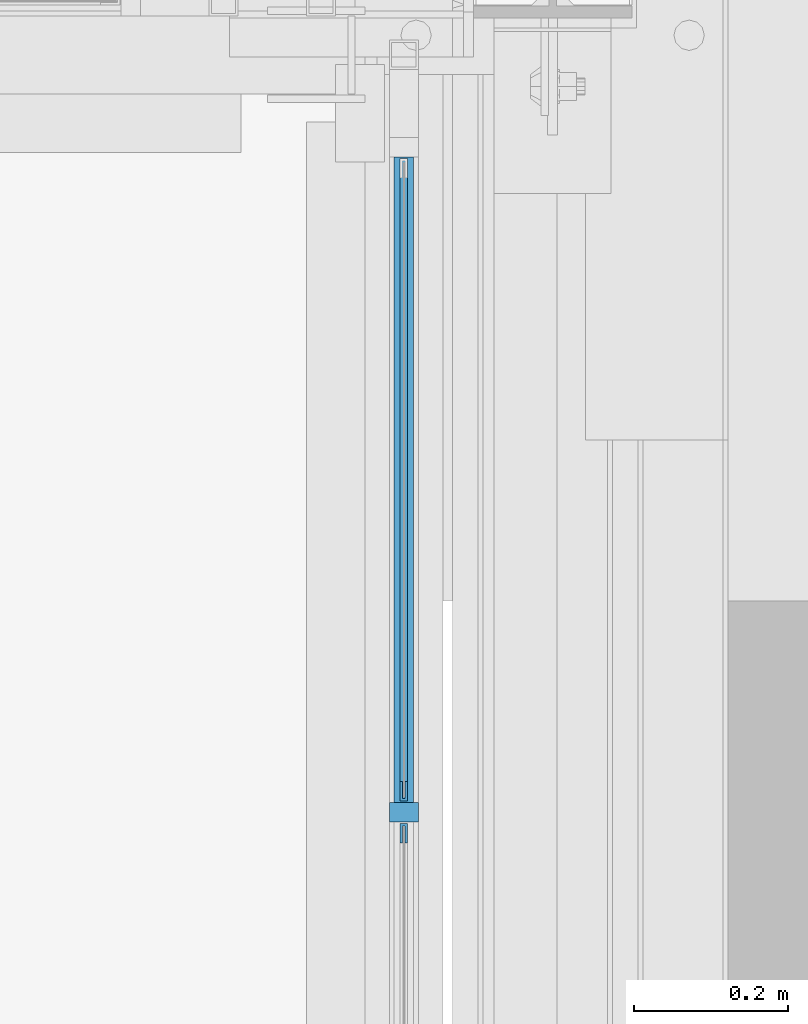
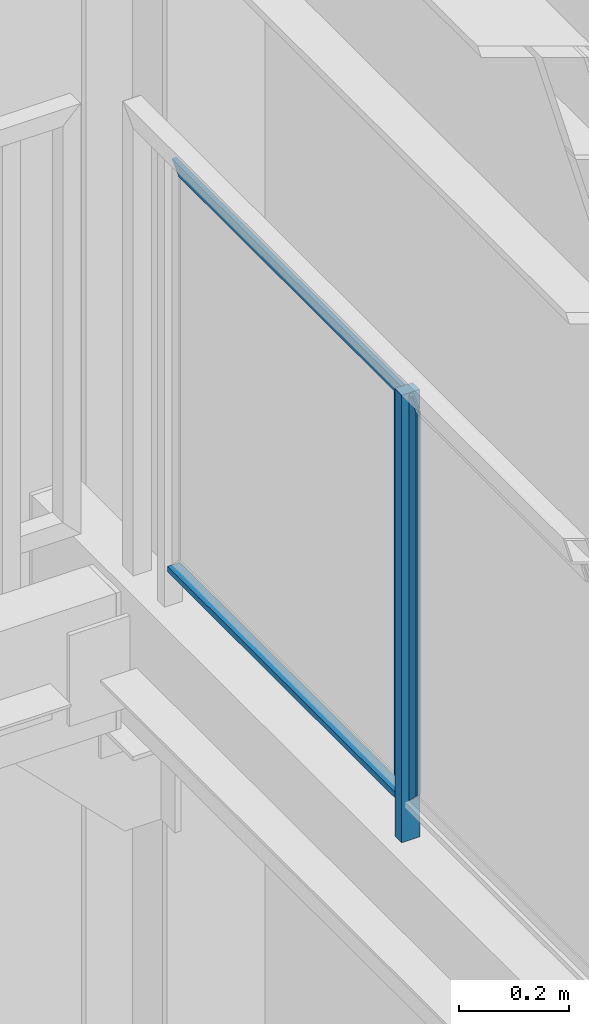
# One storey, part 948 of 1179: 3 beams, 2 members, 1 element without a shape of its own.
"""IFC2X3 building model written with IfcOpenShell, lengths in millimetres."""

from ifc_helpers import new_model, si_unit, frame, origin_with_axes, place, context, subcontext, project, spatial, faceted_brep, material, type_object, element, aggregate, save


model = new_model("IFC2X3")

# Units and contexts
model_context = context("Model", 3, precision=1e-05, world=origin_with_axes())
body_context = subcontext(model_context, "Body", "Model", "MODEL_VIEW")
ifc_project = project(units=[si_unit("LENGTHUNIT", "METRE", prefix="MILLI"), si_unit("AREAUNIT", "SQUARE_METRE"), si_unit("VOLUMEUNIT", "CUBIC_METRE"), si_unit("MASSUNIT", "GRAM", prefix="KILO"), si_unit("TIMEUNIT", "SECOND"), si_unit("PLANEANGLEUNIT", "RADIAN"), si_unit("SOLIDANGLEUNIT", "STERADIAN"), si_unit("THERMODYNAMICTEMPERATUREUNIT", "DEGREE_CELSIUS"), si_unit("LUMINOUSINTENSITYUNIT", "LUMEN")], contexts=[model_context])

# Site, building, storey
site_placement = place(None, origin_with_axes())
site = spatial("IfcSite", under=ifc_project, at=site_placement, CompositionType="ELEMENT")
building_placement = place(site_placement, origin_with_axes())
building = spatial("IfcBuilding", under=site, at=building_placement, Name="Undefined", CompositionType="ELEMENT")
storey_placement = place(building_placement, origin_with_axes())
storey = spatial("IfcBuildingStorey", under=building, at=storey_placement, Name="Undefined", CompositionType="ELEMENT", Elevation=0.0)

# Assembly, members, beams
assembly_placement = place(storey_placement, origin_with_axes())
assembly = element("IfcElementAssembly", 1, at=assembly_placement, inside=storey, Name="GUARDRAIL", AssemblyPlace="NOTDEFINED", PredefinedType="RIGID_FRAME")
ifc_material_1 = material(Name="STEEL/A36")
member_type_1 = type_object("IfcMemberType", PredefinedType="NOTDEFINED")
member_1_placement = place(assembly_placement, frame((24114.1250004143, 40009.2333333341, 6242.04999903482), z_axis=(-1.0, 0.0, 0.0), x_axis=(0.0, 0.0, 1.0)))
member_1 = element("IfcMember", 2, at=member_1_placement, type_object=member_type_1, material=ifc_material_1, Name="POST", context=body_context, shape_type="Brep", body=[
    faceted_brep([(0.0, 12.7000000000007, -19.0500000000029), (0.0, 12.7000000000007, 19.0500000000029), (996.950000401505, 12.6999999999971, 19.0499999999993), (996.950000401505, 12.6999999999971, -19.0499999999993), (0.0, -12.7000000000007, 19.0500000000029), (996.950000401505, -12.6999999999971, 19.0499999999993), (0.0, -12.7000000000007, -19.0500000000029), (996.950000401505, -12.6999999999971, -19.0499999999993)], [[[0, 1, 2, 3]], [[1, 4, 5, 2]], [[4, 6, 7, 5]], [[6, 0, 3, 7]], [[5, 7, 3, 2]], [[6, 4, 1, 0]]]),
])
ifc_material_2 = material(Name="STEEL/BUY-OUT")
beam_type = type_object("IfcBeamType", PredefinedType="NOTDEFINED")
beam_1_placement = place(assembly_placement, frame((24110.9500703529, 40049.0526242175, 6784.97499897165), z_axis=(0.0, 0.0, 1.0), x_axis=(0.0, -1.0, 0.0)))
beam_1 = element("IfcBeam", 3, at=beam_1_placement, type_object=beam_type, material=ifc_material_2, Name="U-EDGE", context=body_context, shape_type="Brep", body=[
    faceted_brep([(0.0, 1.58750000000146, -427.037571475466), (22.2249999999985, 1.58750000000146, -449.262071101228), (22.2249999999985, 4.76249999999709, -449.262071101228), (0.0, 4.76249999999709, -427.037571475466), (0.0, 7.9375, -427.037571475466), (25.4000000000015, 7.9375, -452.4375), (25.4000000000015, -1.58750000000146, -452.4375), (0.0, -1.58750000000146, -427.037571475466), (25.4000000000015, -1.58750000000146, 452.4375), (0.0, -1.58750000000146, 427.037500076054), (0.0, 1.58750000000146, 427.037500076054), (22.2249999999985, 1.58750000000146, 449.262500000033), (22.2249999999985, 4.76249999999709, 449.262500000033), (0.0, 4.76249999999709, 427.037500000033), (0.0, 7.9375, 427.037500000033), (25.4000000000015, 7.9375, 452.4375)], [[[0, 1, 2, 3, 4, 5, 6, 7]], [[7, 6, 8, 9]], [[0, 7, 9, 10]], [[1, 0, 10, 11]], [[2, 1, 11, 12]], [[3, 2, 12, 13]], [[4, 3, 13, 14]], [[5, 4, 14, 15]], [[6, 5, 15, 8]], [[14, 13, 12, 11, 10, 9, 8, 15]]]),
])
beam_2_placement = place(assembly_placement, frame((24110.9502052178, 40441.9591242175, 7212.01249897166), z_axis=(0.0, 1.0, 0.0), x_axis=(0.0, 0.0, 1.0)))
beam_2 = element("IfcBeam", 4, at=beam_2_placement, type_object=beam_type, material=ifc_material_2, Name="U-EDGE", context=body_context, shape_type="Brep", body=[
    faceted_brep([(0.0, 1.58750000000146, -392.906500000216), (22.2249999999785, 1.58750000000146, -415.131500000192), (22.2249999999603, 4.76236513509502, -415.131500000178), (-5.54791768081486e-11, 4.76236513509502, -392.906500000165), (-5.54791768081486e-11, 7.93736513509793, -392.906500000165), (25.3999999999414, 7.93736513509793, -418.306499999999), (25.3999999999969, -1.58750000000146, -418.306499999999), (0.0, -1.58750000000146, -392.906500000216), (25.3999999999969, -1.58750000000146, 418.306499999999), (0.0, -1.58750000000146, 392.90650078046), (0.0, 1.58750000000146, 392.90650078046), (22.2249999999785, 1.58750000000146, 415.131500780415), (22.2249999999603, 4.76236513509502, 415.131500780393), (-5.54791768081486e-11, 4.76236513509502, 392.90650078038), (-5.54791768081486e-11, 7.93736513509793, 392.90650078038), (25.3999999999414, 7.93736513509793, 418.306499999999)], [[[0, 1, 2, 3, 4, 5, 6, 7]], [[7, 6, 8, 9]], [[0, 7, 9, 10]], [[1, 0, 10, 11]], [[2, 1, 11, 12]], [[3, 2, 12, 13]], [[4, 3, 13, 14]], [[5, 4, 14, 15]], [[6, 5, 15, 8]], [[14, 13, 12, 11, 10, 9, 8, 15]]]),
])
beam_3_placement = place(assembly_placement, frame((24110.9500703529, 39969.1489583341, 6784.97499945383), z_axis=(0.0, 0.0, 1.0), x_axis=(0.0, 1.0, 0.0)))
beam_3 = element("IfcBeam", 5, at=beam_3_placement, type_object=beam_type, material=ifc_material_2, Name="U-EDGE", context=body_context, shape_type="Brep", body=[
    faceted_brep([(2.91038304567337e-11, -4.76249999999709, -427.037499923914), (22.2250000000131, -4.76249999999709, -449.2624999239), (22.2250000000131, -1.58750000000146, -449.2624999239), (0.0, -1.58750000000146, -427.037499923886), (0.0, 1.58750000000146, -427.037499923886), (25.4000000439901, 1.58750000000146, -452.437500000357), (25.4000000476099, -7.93749999539432, -452.437500000422), (2.91038304567337e-11, -7.9375, -427.037499923914), (25.4000000000647, -7.9375, 452.4375), (1.29148247651756e-10, -7.9375, 427.037500076181), (1.29148247651756e-10, -4.76249999999709, 427.037500076181), (22.2250000000645, -4.76249999999709, 449.262500076118), (22.2250000000645, -1.58750000000146, 449.262500076118), (0.0, -1.58750000000146, 427.037500076054), (0.0, 1.58750000000146, 427.037500076054), (25.4000000000647, 1.58750000000146, 452.4375)], [[[0, 1, 2, 3, 4, 5, 6, 7]], [[8, 9, 7, 6]], [[9, 10, 0, 7]], [[10, 11, 1, 0]], [[11, 12, 2, 1]], [[12, 13, 3, 2]], [[13, 14, 4, 3]], [[14, 15, 5, 4]], [[15, 8, 6, 5]], [[14, 13, 12, 11, 10, 9, 8, 15]]]),
])
member_type_2 = type_object("IfcMemberType", PredefinedType="NOTDEFINED")
member_2_placement = place(assembly_placement, frame((24114.1250004143, 40009.2333333341, 6324.60000042314), z_axis=(1.0, 0.0, 0.0), x_axis=(0.0, 1.0, 0.0)))
member_2 = element("IfcMember", 6, at=member_2_placement, type_object=member_type_2, material=ifc_material_1, Name="BOTTOM_RAIL", context=body_context, shape_type="Brep", body=[
    faceted_brep([(12.6999999999971, 6.35000000000036, -12.7000000000007), (12.6999999999971, 6.35000000000036, 12.7000000000007), (853.01666666659, 6.35000000000036, 12.7000000000007), (853.01666666659, 6.35000000000036, -12.7000000000007), (12.6999999999971, -6.35000000000036, 12.7000000000007), (853.01666666659, -6.35000000000036, 12.7000000000007), (12.6999999999971, -6.35000000000036, -12.7000000000007), (853.01666666659, -6.35000000000036, -12.7000000000007)], [[[0, 1, 2, 3]], [[1, 4, 5, 2]], [[4, 6, 7, 5]], [[6, 0, 3, 7]], [[5, 7, 3, 2]], [[6, 4, 1, 0]]]),
])
aggregate(assembly, [beam_1, beam_2, beam_3, member_1, member_2])

save(model, "model.ifc")
